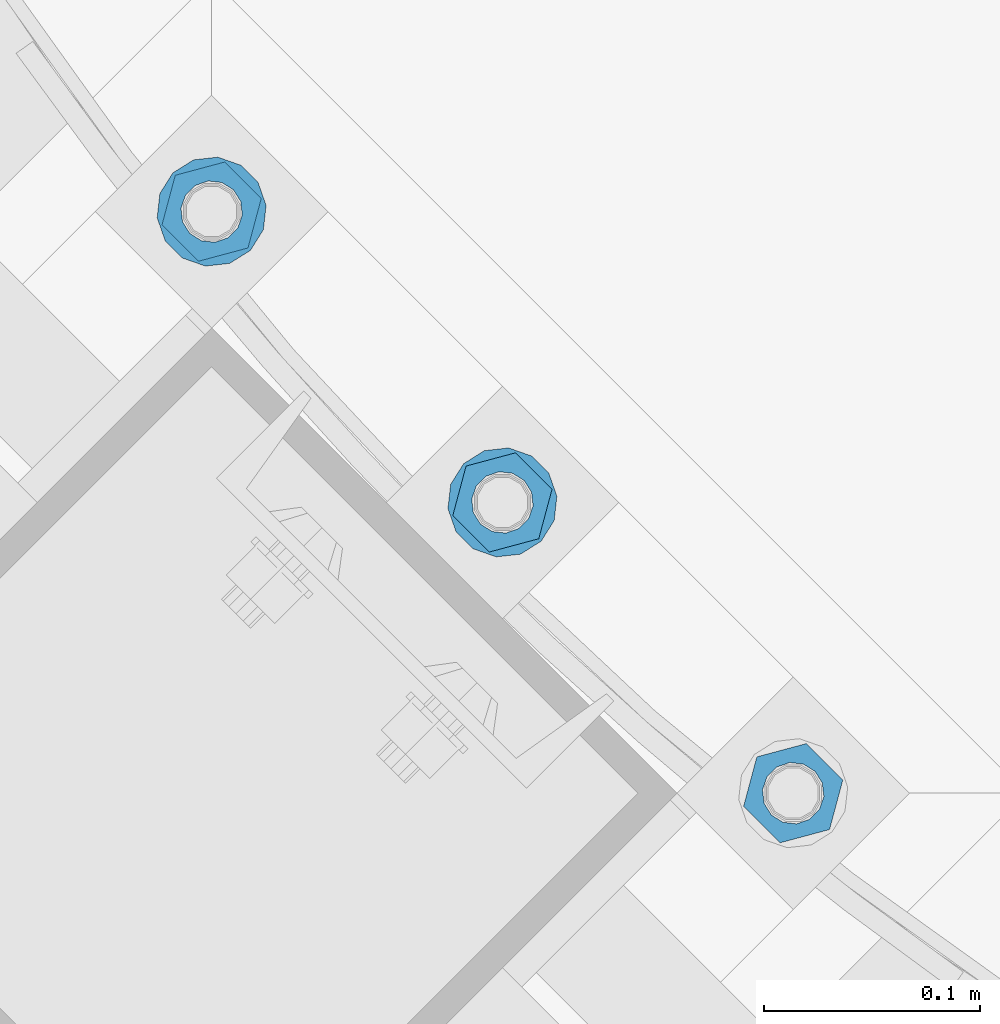
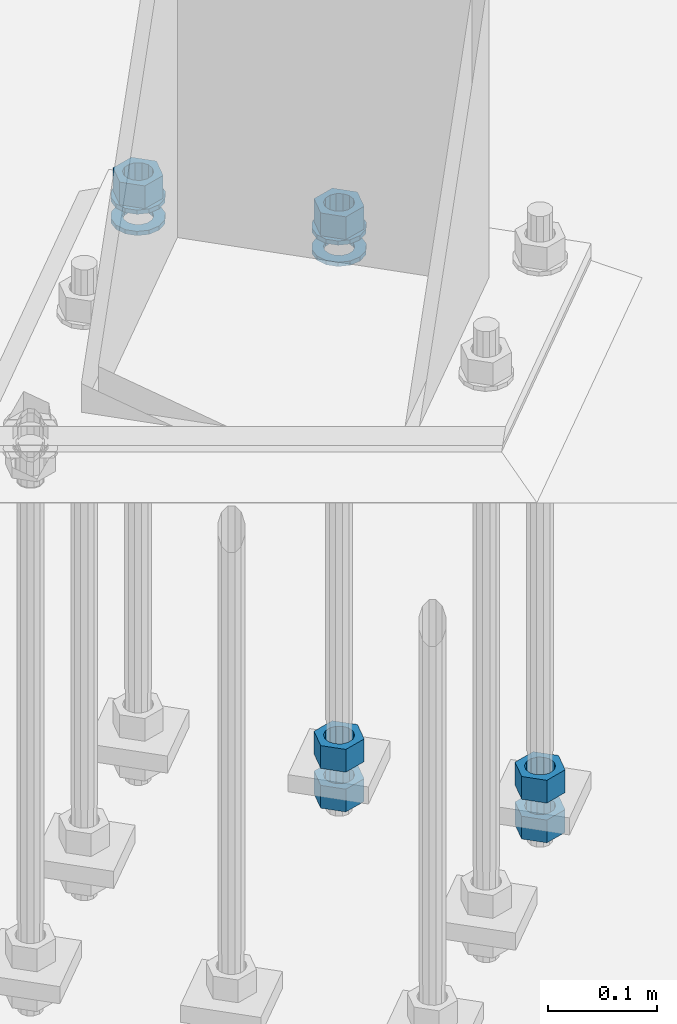
# One storey, part 879 of 1876: 10 columns, 1 element without a shape of its own.
"""IFC2X3 building model written with IfcOpenShell, lengths in millimetres."""

from ifc_helpers import new_model, si_unit, frame, origin_with_axes, place, context, subcontext, project, spatial, faceted_brep, material, type_object, element, aggregate, save


model = new_model("IFC2X3")

# Units and contexts
model_context = context("Model", 3, precision=1e-05, world=origin_with_axes())
body_context = subcontext(model_context, "Body", "Model", "MODEL_VIEW")
ifc_project = project(units=[si_unit("LENGTHUNIT", "METRE", prefix="MILLI"), si_unit("AREAUNIT", "SQUARE_METRE"), si_unit("VOLUMEUNIT", "CUBIC_METRE"), si_unit("MASSUNIT", "GRAM", prefix="KILO"), si_unit("TIMEUNIT", "SECOND"), si_unit("PLANEANGLEUNIT", "RADIAN"), si_unit("SOLIDANGLEUNIT", "STERADIAN"), si_unit("THERMODYNAMICTEMPERATUREUNIT", "DEGREE_CELSIUS"), si_unit("LUMINOUSINTENSITYUNIT", "LUMEN")], contexts=[model_context])

# Site, building, storey
site_placement = place(None, origin_with_axes())
site = spatial("IfcSite", under=ifc_project, at=site_placement, CompositionType="ELEMENT")
building_placement = place(site_placement, origin_with_axes())
building = spatial("IfcBuilding", under=site, at=building_placement, Name="Undefined", CompositionType="ELEMENT")
storey_placement = place(building_placement, origin_with_axes())
storey = spatial("IfcBuildingStorey", under=building, at=storey_placement, Name="Undefined", CompositionType="ELEMENT", Elevation=0.0)

# Assembly, columns
assembly_placement = place(storey_placement, origin_with_axes())
assembly = element("IfcElementAssembly", 1, at=assembly_placement, inside=storey, Name="TEMPLATE", AssemblyPlace="NOTDEFINED", PredefinedType="RIGID_FRAME")
ifc_material_1 = material(Name="STEEL/A563")
column_type_1 = type_object("IfcColumnType", Name="1_HEAVY_HEX_NUT", PredefinedType="NOTDEFINED")
column_1_placement = place(assembly_placement, frame((4052.33317214106, -10936.3778259279, -508.0), z_axis=(0.707106781186548, 0.707106781186547, 0.0), x_axis=(0.0, 0.0, -1.0)))
column_1 = element("IfcColumn", 2, at=column_1_placement, type_object=column_type_1, material=ifc_material_1, Name="NUT", ObjectType="1_HEAVY_HEX_NUT", context=body_context, shape_type="Brep", body=[
    faceted_brep([(0.0, -23.8099994659442, 9.09494701772928e-13), (0.0, -11.9099998474121, -20.6200008392352), (25.4, -11.9099998474157, -20.6200008392361), (25.4, -23.8099994659478, 0.0), (0.0, 11.9099998474157, -20.620000839237), (25.4, 11.9099998474121, -20.620000839237), (0.0, 23.8099994659478, 9.09494701772928e-13), (25.4, 23.8099994659442, 0.0), (0.0, 11.9099998474157, 20.620000839237), (25.4, 11.9099998474121, 20.620000839237), (0.0, -11.9099998474121, 20.6200008392389), (25.4, -11.9099998474157, 20.6200008392379), (0.0, 1.81898940354586e-12, 14.2899999618567), (0.0, 6.20019861543915, 12.8748450879584), (25.4, 6.20019861543733, 12.8748450879593), (25.4, 0.0, 14.2899999618558), (0.0, 11.1723718546473, 8.90966924477925), (25.4, 11.1723718546436, 8.90966924477925), (0.0, 13.9317198278914, 3.17982413774916), (25.4, 13.9317198278877, 3.17982413775007), (0.0, 13.9317198278914, -3.17982413774644), (25.4, 13.9317198278895, -3.17982413774735), (0.0, 11.1723718546473, -8.90966924477834), (25.4, 11.1723718546455, -8.90966924477925), (0.0, 6.20019861544279, -12.8748450879575), (25.4, 6.20019861543915, -12.8748450879584), (0.0, 3.63797880709171e-12, -14.2899999618548), (25.4, -3.63797880709171e-12, -14.2899999618548), (0.0, -6.20019861543733, -12.8748450879566), (25.4, -6.20019861544097, -12.8748450879584), (0.0, -11.1723718546455, -8.90966924477743), (25.4, -11.1723718546473, -8.90966924477834), (0.0, -13.9317198278877, -3.17982413774735), (25.4, -13.9317198278914, -3.17982413774826), (0.0, -13.9317198278895, 3.17982413774735), (25.4, -13.9317198278914, 3.17982413774826), (0.0, -11.1723718546455, 8.90966924477925), (25.4, -11.1723718546473, 8.90966924478016), (0.0, -6.20019861543915, 12.8748450879593), (25.4, -6.20019861544279, 12.8748450879593)], [[[0, 1, 2, 3]], [[1, 4, 5, 2]], [[4, 6, 7, 5]], [[6, 8, 9, 7]], [[8, 10, 11, 9]], [[10, 0, 3, 11]], [[12, 13, 14, 15]], [[13, 16, 17, 14]], [[16, 18, 19, 17]], [[18, 20, 21, 19]], [[20, 22, 23, 21]], [[22, 24, 25, 23]], [[24, 26, 27, 25]], [[26, 28, 29, 27]], [[28, 30, 31, 29]], [[30, 32, 33, 31]], [[32, 34, 35, 33]], [[34, 36, 37, 35]], [[36, 38, 39, 37]], [[38, 12, 15, 39]], [[5, 7, 9, 11, 3, 2], [17, 19, 21, 23, 25, 27, 29, 31, 33, 35, 37, 39, 15, 14]], [[10, 8, 6, 4, 1, 0], [38, 36, 34, 32, 30, 28, 26, 24, 22, 20, 18, 16, 13, 12]]]),
])
column_2_placement = place(assembly_placement, frame((4052.33317214106, -10936.3778259279, -552.45), z_axis=(0.707106781186548, 0.707106781186547, 0.0), x_axis=(0.0, 0.0, -1.0)))
column_2 = element("IfcColumn", 3, at=column_2_placement, type_object=column_type_1, material=ifc_material_1, Name="NUT", ObjectType="1_HEAVY_HEX_NUT", context=body_context, shape_type="Brep", body=[
    faceted_brep([(0.0, -23.8099994659442, 9.09494701772928e-13), (0.0, -11.9099998474121, -20.6200008392352), (25.4, -11.9099998474157, -20.6200008392361), (25.4, -23.8099994659478, 0.0), (0.0, 11.9099998474157, -20.620000839237), (25.4, 11.9099998474121, -20.620000839237), (0.0, 23.8099994659478, 9.09494701772928e-13), (25.4, 23.8099994659442, 0.0), (0.0, 11.9099998474157, 20.620000839237), (25.4, 11.9099998474121, 20.620000839237), (0.0, -11.9099998474121, 20.6200008392389), (25.4, -11.9099998474157, 20.6200008392379), (0.0, 1.81898940354586e-12, 14.2899999618567), (0.0, 6.20019861543915, 12.8748450879584), (25.4, 6.20019861543733, 12.8748450879593), (25.4, 0.0, 14.2899999618558), (0.0, 11.1723718546473, 8.90966924477925), (25.4, 11.1723718546436, 8.90966924477925), (0.0, 13.9317198278914, 3.17982413774916), (25.4, 13.9317198278877, 3.17982413775007), (0.0, 13.9317198278914, -3.17982413774644), (25.4, 13.9317198278895, -3.17982413774735), (0.0, 11.1723718546473, -8.90966924477834), (25.4, 11.1723718546455, -8.90966924477925), (0.0, 6.20019861544279, -12.8748450879575), (25.4, 6.20019861543915, -12.8748450879584), (0.0, 3.63797880709171e-12, -14.2899999618548), (25.4, -3.63797880709171e-12, -14.2899999618548), (0.0, -6.20019861543733, -12.8748450879566), (25.4, -6.20019861544097, -12.8748450879584), (0.0, -11.1723718546455, -8.90966924477743), (25.4, -11.1723718546473, -8.90966924477834), (0.0, -13.9317198278877, -3.17982413774735), (25.4, -13.9317198278914, -3.17982413774826), (0.0, -13.9317198278895, 3.17982413774735), (25.4, -13.9317198278914, 3.17982413774826), (0.0, -11.1723718546455, 8.90966924477925), (25.4, -11.1723718546473, 8.90966924478016), (0.0, -6.20019861543915, 12.8748450879593), (25.4, -6.20019861544279, 12.8748450879593)], [[[0, 1, 2, 3]], [[1, 4, 5, 2]], [[4, 6, 7, 5]], [[6, 8, 9, 7]], [[8, 10, 11, 9]], [[10, 0, 3, 11]], [[12, 13, 14, 15]], [[13, 16, 17, 14]], [[16, 18, 19, 17]], [[18, 20, 21, 19]], [[20, 22, 23, 21]], [[22, 24, 25, 23]], [[24, 26, 27, 25]], [[26, 28, 29, 27]], [[28, 30, 31, 29]], [[30, 32, 33, 31]], [[32, 34, 35, 33]], [[34, 36, 37, 35]], [[36, 38, 39, 37]], [[38, 12, 15, 39]], [[5, 7, 9, 11, 3, 2], [17, 19, 21, 23, 25, 27, 29, 31, 33, 35, 37, 39, 15, 14]], [[10, 8, 6, 4, 1, 0], [38, 36, 34, 32, 30, 28, 26, 24, 22, 20, 18, 16, 13, 12]]]),
])
column_3_placement = place(assembly_placement, frame((3917.62933032491, -10801.6739841117, 87.3125), z_axis=(0.707106781186548, 0.707106781186547, 0.0), x_axis=(0.0, 0.0, -1.0)))
column_3 = element("IfcColumn", 4, at=column_3_placement, type_object=column_type_1, material=ifc_material_1, Name="NUT", ObjectType="1_HEAVY_HEX_NUT", context=body_context, shape_type="Brep", body=[
    faceted_brep([(0.0, -23.8099994659442, 9.09494701772928e-13), (0.0, -11.9099998474121, -20.6200008392352), (25.4, -11.9099998474157, -20.6200008392361), (25.4, -23.8099994659478, 0.0), (0.0, 11.9099998474157, -20.620000839237), (25.4, 11.9099998474121, -20.620000839237), (0.0, 23.8099994659478, 9.09494701772928e-13), (25.4, 23.8099994659442, 0.0), (0.0, 11.9099998474157, 20.620000839237), (25.4, 11.9099998474121, 20.620000839237), (0.0, -11.9099998474121, 20.6200008392389), (25.4, -11.9099998474157, 20.6200008392379), (0.0, 1.81898940354586e-12, 14.2899999618567), (0.0, 6.20019861543915, 12.8748450879584), (25.4, 6.20019861543733, 12.8748450879593), (25.4, 0.0, 14.2899999618558), (0.0, 11.1723718546473, 8.90966924477925), (25.4, 11.1723718546436, 8.90966924477925), (0.0, 13.9317198278914, 3.17982413774916), (25.4, 13.9317198278877, 3.17982413775007), (0.0, 13.9317198278914, -3.17982413774644), (25.4, 13.9317198278895, -3.17982413774735), (0.0, 11.1723718546473, -8.90966924477834), (25.4, 11.1723718546455, -8.90966924477925), (0.0, 6.20019861544279, -12.8748450879575), (25.4, 6.20019861543915, -12.8748450879584), (0.0, 3.63797880709171e-12, -14.2899999618548), (25.4, -3.63797880709171e-12, -14.2899999618548), (0.0, -6.20019861543733, -12.8748450879566), (25.4, -6.20019861544097, -12.8748450879584), (0.0, -11.1723718546455, -8.90966924477743), (25.4, -11.1723718546473, -8.90966924477834), (0.0, -13.9317198278877, -3.17982413774735), (25.4, -13.9317198278914, -3.17982413774826), (0.0, -13.9317198278895, 3.17982413774735), (25.4, -13.9317198278914, 3.17982413774826), (0.0, -11.1723718546455, 8.90966924477925), (25.4, -11.1723718546473, 8.90966924478016), (0.0, -6.20019861543915, 12.8748450879593), (25.4, -6.20019861544279, 12.8748450879593)], [[[0, 1, 2, 3]], [[1, 4, 5, 2]], [[4, 6, 7, 5]], [[6, 8, 9, 7]], [[8, 10, 11, 9]], [[10, 0, 3, 11]], [[12, 13, 14, 15]], [[13, 16, 17, 14]], [[16, 18, 19, 17]], [[18, 20, 21, 19]], [[20, 22, 23, 21]], [[22, 24, 25, 23]], [[24, 26, 27, 25]], [[26, 28, 29, 27]], [[28, 30, 31, 29]], [[30, 32, 33, 31]], [[32, 34, 35, 33]], [[34, 36, 37, 35]], [[36, 38, 39, 37]], [[38, 12, 15, 39]], [[5, 7, 9, 11, 3, 2], [17, 19, 21, 23, 25, 27, 29, 31, 33, 35, 37, 39, 15, 14]], [[10, 8, 6, 4, 1, 0], [38, 36, 34, 32, 30, 28, 26, 24, 22, 20, 18, 16, 13, 12]]]),
])
column_4_placement = place(assembly_placement, frame((3917.62933032491, -10801.6739841117, -508.0), z_axis=(0.707106781186548, 0.707106781186547, 0.0), x_axis=(0.0, 0.0, -1.0)))
column_4 = element("IfcColumn", 5, at=column_4_placement, type_object=column_type_1, material=ifc_material_1, Name="NUT", ObjectType="1_HEAVY_HEX_NUT", context=body_context, shape_type="Brep", body=[
    faceted_brep([(0.0, -23.8099994659442, 9.09494701772928e-13), (0.0, -11.9099998474121, -20.6200008392352), (25.4, -11.9099998474157, -20.6200008392361), (25.4, -23.8099994659478, 0.0), (0.0, 11.9099998474157, -20.620000839237), (25.4, 11.9099998474121, -20.620000839237), (0.0, 23.8099994659478, 9.09494701772928e-13), (25.4, 23.8099994659442, 0.0), (0.0, 11.9099998474157, 20.620000839237), (25.4, 11.9099998474121, 20.620000839237), (0.0, -11.9099998474121, 20.6200008392389), (25.4, -11.9099998474157, 20.6200008392379), (0.0, 1.81898940354586e-12, 14.2899999618567), (0.0, 6.20019861543915, 12.8748450879584), (25.4, 6.20019861543733, 12.8748450879593), (25.4, 0.0, 14.2899999618558), (0.0, 11.1723718546473, 8.90966924477925), (25.4, 11.1723718546436, 8.90966924477925), (0.0, 13.9317198278914, 3.17982413774916), (25.4, 13.9317198278877, 3.17982413775007), (0.0, 13.9317198278914, -3.17982413774644), (25.4, 13.9317198278895, -3.17982413774735), (0.0, 11.1723718546473, -8.90966924477834), (25.4, 11.1723718546455, -8.90966924477925), (0.0, 6.20019861544279, -12.8748450879575), (25.4, 6.20019861543915, -12.8748450879584), (0.0, 3.63797880709171e-12, -14.2899999618548), (25.4, -3.63797880709171e-12, -14.2899999618548), (0.0, -6.20019861543733, -12.8748450879566), (25.4, -6.20019861544097, -12.8748450879584), (0.0, -11.1723718546455, -8.90966924477743), (25.4, -11.1723718546473, -8.90966924477834), (0.0, -13.9317198278877, -3.17982413774735), (25.4, -13.9317198278914, -3.17982413774826), (0.0, -13.9317198278895, 3.17982413774735), (25.4, -13.9317198278914, 3.17982413774826), (0.0, -11.1723718546455, 8.90966924477925), (25.4, -11.1723718546473, 8.90966924478016), (0.0, -6.20019861543915, 12.8748450879593), (25.4, -6.20019861544279, 12.8748450879593)], [[[0, 1, 2, 3]], [[1, 4, 5, 2]], [[4, 6, 7, 5]], [[6, 8, 9, 7]], [[8, 10, 11, 9]], [[10, 0, 3, 11]], [[12, 13, 14, 15]], [[13, 16, 17, 14]], [[16, 18, 19, 17]], [[18, 20, 21, 19]], [[20, 22, 23, 21]], [[22, 24, 25, 23]], [[24, 26, 27, 25]], [[26, 28, 29, 27]], [[28, 30, 31, 29]], [[30, 32, 33, 31]], [[32, 34, 35, 33]], [[34, 36, 37, 35]], [[36, 38, 39, 37]], [[38, 12, 15, 39]], [[5, 7, 9, 11, 3, 2], [17, 19, 21, 23, 25, 27, 29, 31, 33, 35, 37, 39, 15, 14]], [[10, 8, 6, 4, 1, 0], [38, 36, 34, 32, 30, 28, 26, 24, 22, 20, 18, 16, 13, 12]]]),
])
column_5_placement = place(assembly_placement, frame((3917.62933032491, -10801.6739841117, -552.45), z_axis=(0.707106781186548, 0.707106781186547, 0.0), x_axis=(0.0, 0.0, -1.0)))
column_5 = element("IfcColumn", 6, at=column_5_placement, type_object=column_type_1, material=ifc_material_1, Name="NUT", ObjectType="1_HEAVY_HEX_NUT", context=body_context, shape_type="Brep", body=[
    faceted_brep([(0.0, -23.8099994659442, 9.09494701772928e-13), (0.0, -11.9099998474121, -20.6200008392352), (25.4, -11.9099998474157, -20.6200008392361), (25.4, -23.8099994659478, 0.0), (0.0, 11.9099998474157, -20.620000839237), (25.4, 11.9099998474121, -20.620000839237), (0.0, 23.8099994659478, 9.09494701772928e-13), (25.4, 23.8099994659442, 0.0), (0.0, 11.9099998474157, 20.620000839237), (25.4, 11.9099998474121, 20.620000839237), (0.0, -11.9099998474121, 20.6200008392389), (25.4, -11.9099998474157, 20.6200008392379), (0.0, 1.81898940354586e-12, 14.2899999618567), (0.0, 6.20019861543915, 12.8748450879584), (25.4, 6.20019861543733, 12.8748450879593), (25.4, 0.0, 14.2899999618558), (0.0, 11.1723718546473, 8.90966924477925), (25.4, 11.1723718546436, 8.90966924477925), (0.0, 13.9317198278914, 3.17982413774916), (25.4, 13.9317198278877, 3.17982413775007), (0.0, 13.9317198278914, -3.17982413774644), (25.4, 13.9317198278895, -3.17982413774735), (0.0, 11.1723718546473, -8.90966924477834), (25.4, 11.1723718546455, -8.90966924477925), (0.0, 6.20019861544279, -12.8748450879575), (25.4, 6.20019861543915, -12.8748450879584), (0.0, 3.63797880709171e-12, -14.2899999618548), (25.4, -3.63797880709171e-12, -14.2899999618548), (0.0, -6.20019861543733, -12.8748450879566), (25.4, -6.20019861544097, -12.8748450879584), (0.0, -11.1723718546455, -8.90966924477743), (25.4, -11.1723718546473, -8.90966924477834), (0.0, -13.9317198278877, -3.17982413774735), (25.4, -13.9317198278914, -3.17982413774826), (0.0, -13.9317198278895, 3.17982413774735), (25.4, -13.9317198278914, 3.17982413774826), (0.0, -11.1723718546455, 8.90966924477925), (25.4, -11.1723718546473, 8.90966924478016), (0.0, -6.20019861543915, 12.8748450879593), (25.4, -6.20019861544279, 12.8748450879593)], [[[0, 1, 2, 3]], [[1, 4, 5, 2]], [[4, 6, 7, 5]], [[6, 8, 9, 7]], [[8, 10, 11, 9]], [[10, 0, 3, 11]], [[12, 13, 14, 15]], [[13, 16, 17, 14]], [[16, 18, 19, 17]], [[18, 20, 21, 19]], [[20, 22, 23, 21]], [[22, 24, 25, 23]], [[24, 26, 27, 25]], [[26, 28, 29, 27]], [[28, 30, 31, 29]], [[30, 32, 33, 31]], [[32, 34, 35, 33]], [[34, 36, 37, 35]], [[36, 38, 39, 37]], [[38, 12, 15, 39]], [[5, 7, 9, 11, 3, 2], [17, 19, 21, 23, 25, 27, 29, 31, 33, 35, 37, 39, 15, 14]], [[10, 8, 6, 4, 1, 0], [38, 36, 34, 32, 30, 28, 26, 24, 22, 20, 18, 16, 13, 12]]]),
])
column_6_placement = place(assembly_placement, frame((3782.92548850875, -10666.9701422955, 87.3125), z_axis=(-0.707106781186547, -0.707106781186548, 0.0), x_axis=(0.0, 0.0, -1.0)))
column_6 = element("IfcColumn", 7, at=column_6_placement, type_object=column_type_1, material=ifc_material_1, Name="NUT", ObjectType="1_HEAVY_HEX_NUT", context=body_context, shape_type="Brep", body=[
    faceted_brep([(0.0, -23.8099994659442, 9.09494701772928e-13), (0.0, -11.9099998474121, -20.6200008392352), (25.4, -11.9099998474157, -20.6200008392361), (25.4, -23.8099994659478, 0.0), (0.0, 11.9099998474157, -20.620000839237), (25.4, 11.9099998474121, -20.620000839237), (0.0, 23.8099994659478, 9.09494701772928e-13), (25.4, 23.8099994659442, 0.0), (0.0, 11.9099998474157, 20.620000839237), (25.4, 11.9099998474121, 20.620000839237), (0.0, -11.9099998474121, 20.6200008392389), (25.4, -11.9099998474157, 20.6200008392379), (0.0, 1.81898940354586e-12, 14.2899999618567), (0.0, 6.20019861543915, 12.8748450879584), (25.4, 6.20019861543733, 12.8748450879593), (25.4, 0.0, 14.2899999618558), (0.0, 11.1723718546473, 8.90966924477925), (25.4, 11.1723718546436, 8.90966924477925), (0.0, 13.9317198278914, 3.17982413774916), (25.4, 13.9317198278877, 3.17982413775007), (0.0, 13.9317198278914, -3.17982413774644), (25.4, 13.9317198278895, -3.17982413774735), (0.0, 11.1723718546473, -8.90966924477834), (25.4, 11.1723718546455, -8.90966924477925), (0.0, 6.20019861544279, -12.8748450879575), (25.4, 6.20019861543915, -12.8748450879584), (0.0, 3.63797880709171e-12, -14.2899999618548), (25.4, -3.63797880709171e-12, -14.2899999618548), (0.0, -6.20019861543733, -12.8748450879566), (25.4, -6.20019861544097, -12.8748450879584), (0.0, -11.1723718546455, -8.90966924477743), (25.4, -11.1723718546473, -8.90966924477834), (0.0, -13.9317198278877, -3.17982413774735), (25.4, -13.9317198278914, -3.17982413774826), (0.0, -13.9317198278895, 3.17982413774735), (25.4, -13.9317198278914, 3.17982413774826), (0.0, -11.1723718546455, 8.90966924477925), (25.4, -11.1723718546473, 8.90966924478016), (0.0, -6.20019861543915, 12.8748450879593), (25.4, -6.20019861544279, 12.8748450879593)], [[[0, 1, 2, 3]], [[1, 4, 5, 2]], [[4, 6, 7, 5]], [[6, 8, 9, 7]], [[8, 10, 11, 9]], [[10, 0, 3, 11]], [[12, 13, 14, 15]], [[13, 16, 17, 14]], [[16, 18, 19, 17]], [[18, 20, 21, 19]], [[20, 22, 23, 21]], [[22, 24, 25, 23]], [[24, 26, 27, 25]], [[26, 28, 29, 27]], [[28, 30, 31, 29]], [[30, 32, 33, 31]], [[32, 34, 35, 33]], [[34, 36, 37, 35]], [[36, 38, 39, 37]], [[38, 12, 15, 39]], [[5, 7, 9, 11, 3, 2], [17, 19, 21, 23, 25, 27, 29, 31, 33, 35, 37, 39, 15, 14]], [[10, 8, 6, 4, 1, 0], [38, 36, 34, 32, 30, 28, 26, 24, 22, 20, 18, 16, 13, 12]]]),
])
ifc_material_2 = material(Name="STEEL/F436")
column_type_2 = type_object("IfcColumnType", Name="1_WASHER", PredefinedType="NOTDEFINED")
column_7_placement = place(assembly_placement, frame((3917.62933032491, -10801.6739841117, 38.1), z_axis=(0.707106781186548, 0.707106781186547, 0.0), x_axis=(0.0, 0.0, -1.0)))
column_7 = element("IfcColumn", 8, at=column_7_placement, type_object=column_type_2, material=ifc_material_2, Name="WASHER", ObjectType="1_WASHER", context=body_context, shape_type="Brep", body=[
    faceted_brep([(0.0, -25.3999996185375, 0.0), (0.0, -22.8846089010331, -11.0206468080742), (4.7625, -22.8846089010331, -11.0206468080742), (4.7625, -25.3999996185375, 0.0), (0.0, -15.8366407293743, -19.8585193564477), (4.7625, -15.8366407293743, -19.8585193564477), (0.0, -5.65203163760816, -24.7631685975166), (4.7625, -5.65203163760816, -24.7631685975166), (0.0, 5.65203163760452, -24.7631685975166), (4.7625, 5.65203163760452, -24.7631685975166), (0.0, 15.8366407293706, -19.858519356445), (4.7625, 15.8366407293706, -19.858519356445), (0.0, 22.8846089010331, -11.0206468080733), (4.7625, 22.8846089010331, -11.0206468080733), (0.0, 25.3999996185339, 9.09494701772928e-13), (4.7625, 25.3999996185339, 9.09494701772928e-13), (0.0, 22.8846089010331, 11.0206468080751), (4.7625, 22.8846089010331, 11.0206468080751), (0.0, 15.8366407293706, 19.8585193564486), (4.7625, 15.8366407293706, 19.8585193564486), (0.0, 5.65203163760452, 24.7631685975175), (4.7625, 5.65203163760452, 24.7631685975175), (0.0, -5.65203163760816, 24.7631685975175), (4.7625, -5.65203163760816, 24.7631685975175), (0.0, -15.8366407293724, 19.8585193564459), (4.7625, -15.8366407293724, 19.8585193564459), (0.0, -22.8846089010367, 11.0206468080751), (4.7625, -22.8846089010367, 11.0206468080751), (0.0, 1.81898940354586e-12, 14.2899999618567), (0.0, 6.20019861543915, 12.8748450879584), (4.7625, 6.20019861543733, 12.8748450879593), (4.7625, 0.0, 14.2899999618558), (0.0, 11.1723718546473, 8.90966924477925), (4.7625, 11.1723718546436, 8.90966924477925), (0.0, 13.9317198278914, 3.17982413774916), (4.7625, 13.9317198278877, 3.17982413775007), (0.0, 13.9317198278914, -3.17982413774644), (4.7625, 13.9317198278895, -3.17982413774735), (0.0, 11.1723718546473, -8.90966924477834), (4.7625, 11.1723718546455, -8.90966924477925), (0.0, 6.20019861544279, -12.8748450879575), (4.7625, 6.20019861543915, -12.8748450879584), (0.0, 3.63797880709171e-12, -14.2899999618548), (4.7625, -3.63797880709171e-12, -14.2899999618548), (0.0, -6.20019861543733, -12.8748450879566), (4.7625, -6.20019861544097, -12.8748450879584), (0.0, -11.1723718546455, -8.90966924477743), (4.7625, -11.1723718546473, -8.90966924477834), (0.0, -13.9317198278877, -3.17982413774735), (4.7625, -13.9317198278914, -3.17982413774826), (0.0, -13.9317198278895, 3.17982413774735), (4.7625, -13.9317198278914, 3.17982413774826), (0.0, -11.1723718546455, 8.90966924477925), (4.7625, -11.1723718546473, 8.90966924478016), (0.0, -6.20019861543915, 12.8748450879593), (4.7625, -6.20019861544279, 12.8748450879593)], [[[0, 1, 2, 3]], [[1, 4, 5, 2]], [[4, 6, 7, 5]], [[6, 8, 9, 7]], [[8, 10, 11, 9]], [[10, 12, 13, 11]], [[12, 14, 15, 13]], [[14, 16, 17, 15]], [[16, 18, 19, 17]], [[18, 20, 21, 19]], [[20, 22, 23, 21]], [[22, 24, 25, 23]], [[24, 26, 27, 25]], [[26, 0, 3, 27]], [[28, 29, 30, 31]], [[29, 32, 33, 30]], [[32, 34, 35, 33]], [[34, 36, 37, 35]], [[36, 38, 39, 37]], [[38, 40, 41, 39]], [[40, 42, 43, 41]], [[42, 44, 45, 43]], [[44, 46, 47, 45]], [[46, 48, 49, 47]], [[48, 50, 51, 49]], [[50, 52, 53, 51]], [[52, 54, 55, 53]], [[54, 28, 31, 55]], [[5, 7, 9, 11, 13, 15, 17, 19, 21, 23, 25, 27, 3, 2], [33, 35, 37, 39, 41, 43, 45, 47, 49, 51, 53, 55, 31, 30]], [[26, 24, 22, 20, 18, 16, 14, 12, 10, 8, 6, 4, 1, 0], [54, 52, 50, 48, 46, 44, 42, 40, 38, 36, 34, 32, 29, 28]]]),
])
column_8_placement = place(assembly_placement, frame((3917.62933032491, -10801.6739841117, 61.9125), z_axis=(0.707106781186548, 0.707106781186547, 0.0), x_axis=(0.0, 0.0, -1.0)))
column_8 = element("IfcColumn", 9, at=column_8_placement, type_object=column_type_2, material=ifc_material_2, Name="WASHER", ObjectType="1_WASHER", context=body_context, shape_type="Brep", body=[
    faceted_brep([(0.0, -25.3999996185375, 0.0), (0.0, -22.8846089010331, -11.0206468080742), (4.7625, -22.8846089010331, -11.0206468080742), (4.7625, -25.3999996185375, 0.0), (0.0, -15.8366407293743, -19.8585193564477), (4.7625, -15.8366407293743, -19.8585193564477), (0.0, -5.65203163760816, -24.7631685975166), (4.7625, -5.65203163760816, -24.7631685975166), (0.0, 5.65203163760452, -24.7631685975166), (4.7625, 5.65203163760452, -24.7631685975166), (0.0, 15.8366407293706, -19.858519356445), (4.7625, 15.8366407293706, -19.858519356445), (0.0, 22.8846089010331, -11.0206468080733), (4.7625, 22.8846089010331, -11.0206468080733), (0.0, 25.3999996185339, 9.09494701772928e-13), (4.7625, 25.3999996185339, 9.09494701772928e-13), (0.0, 22.8846089010331, 11.0206468080751), (4.7625, 22.8846089010331, 11.0206468080751), (0.0, 15.8366407293706, 19.8585193564486), (4.7625, 15.8366407293706, 19.8585193564486), (0.0, 5.65203163760452, 24.7631685975175), (4.7625, 5.65203163760452, 24.7631685975175), (0.0, -5.65203163760816, 24.7631685975175), (4.7625, -5.65203163760816, 24.7631685975175), (0.0, -15.8366407293724, 19.8585193564459), (4.7625, -15.8366407293724, 19.8585193564459), (0.0, -22.8846089010367, 11.0206468080751), (4.7625, -22.8846089010367, 11.0206468080751), (0.0, 1.81898940354586e-12, 14.2899999618567), (0.0, 6.20019861543915, 12.8748450879584), (4.7625, 6.20019861543733, 12.8748450879593), (4.7625, 0.0, 14.2899999618558), (0.0, 11.1723718546473, 8.90966924477925), (4.7625, 11.1723718546436, 8.90966924477925), (0.0, 13.9317198278914, 3.17982413774916), (4.7625, 13.9317198278877, 3.17982413775007), (0.0, 13.9317198278914, -3.17982413774644), (4.7625, 13.9317198278895, -3.17982413774735), (0.0, 11.1723718546473, -8.90966924477834), (4.7625, 11.1723718546455, -8.90966924477925), (0.0, 6.20019861544279, -12.8748450879575), (4.7625, 6.20019861543915, -12.8748450879584), (0.0, 3.63797880709171e-12, -14.2899999618548), (4.7625, -3.63797880709171e-12, -14.2899999618548), (0.0, -6.20019861543733, -12.8748450879566), (4.7625, -6.20019861544097, -12.8748450879584), (0.0, -11.1723718546455, -8.90966924477743), (4.7625, -11.1723718546473, -8.90966924477834), (0.0, -13.9317198278877, -3.17982413774735), (4.7625, -13.9317198278914, -3.17982413774826), (0.0, -13.9317198278895, 3.17982413774735), (4.7625, -13.9317198278914, 3.17982413774826), (0.0, -11.1723718546455, 8.90966924477925), (4.7625, -11.1723718546473, 8.90966924478016), (0.0, -6.20019861543915, 12.8748450879593), (4.7625, -6.20019861544279, 12.8748450879593)], [[[0, 1, 2, 3]], [[1, 4, 5, 2]], [[4, 6, 7, 5]], [[6, 8, 9, 7]], [[8, 10, 11, 9]], [[10, 12, 13, 11]], [[12, 14, 15, 13]], [[14, 16, 17, 15]], [[16, 18, 19, 17]], [[18, 20, 21, 19]], [[20, 22, 23, 21]], [[22, 24, 25, 23]], [[24, 26, 27, 25]], [[26, 0, 3, 27]], [[28, 29, 30, 31]], [[29, 32, 33, 30]], [[32, 34, 35, 33]], [[34, 36, 37, 35]], [[36, 38, 39, 37]], [[38, 40, 41, 39]], [[40, 42, 43, 41]], [[42, 44, 45, 43]], [[44, 46, 47, 45]], [[46, 48, 49, 47]], [[48, 50, 51, 49]], [[50, 52, 53, 51]], [[52, 54, 55, 53]], [[54, 28, 31, 55]], [[5, 7, 9, 11, 13, 15, 17, 19, 21, 23, 25, 27, 3, 2], [33, 35, 37, 39, 41, 43, 45, 47, 49, 51, 53, 55, 31, 30]], [[26, 24, 22, 20, 18, 16, 14, 12, 10, 8, 6, 4, 1, 0], [54, 52, 50, 48, 46, 44, 42, 40, 38, 36, 34, 32, 29, 28]]]),
])
column_9_placement = place(assembly_placement, frame((3782.92548850875, -10666.9701422955, 38.1), z_axis=(-0.707106781186547, -0.707106781186548, 0.0), x_axis=(0.0, 0.0, -1.0)))
column_9 = element("IfcColumn", 10, at=column_9_placement, type_object=column_type_2, material=ifc_material_2, Name="WASHER", ObjectType="1_WASHER", context=body_context, shape_type="Brep", body=[
    faceted_brep([(0.0, -25.3999996185375, 0.0), (0.0, -22.8846089010331, -11.0206468080742), (4.7625, -22.8846089010331, -11.0206468080742), (4.7625, -25.3999996185375, 0.0), (0.0, -15.8366407293743, -19.8585193564477), (4.7625, -15.8366407293743, -19.8585193564477), (0.0, -5.65203163760816, -24.7631685975166), (4.7625, -5.65203163760816, -24.7631685975166), (0.0, 5.65203163760452, -24.7631685975166), (4.7625, 5.65203163760452, -24.7631685975166), (0.0, 15.8366407293706, -19.858519356445), (4.7625, 15.8366407293706, -19.858519356445), (0.0, 22.8846089010331, -11.0206468080733), (4.7625, 22.8846089010331, -11.0206468080733), (0.0, 25.3999996185339, 9.09494701772928e-13), (4.7625, 25.3999996185339, 9.09494701772928e-13), (0.0, 22.8846089010331, 11.0206468080751), (4.7625, 22.8846089010331, 11.0206468080751), (0.0, 15.8366407293706, 19.8585193564486), (4.7625, 15.8366407293706, 19.8585193564486), (0.0, 5.65203163760452, 24.7631685975175), (4.7625, 5.65203163760452, 24.7631685975175), (0.0, -5.65203163760816, 24.7631685975175), (4.7625, -5.65203163760816, 24.7631685975175), (0.0, -15.8366407293724, 19.8585193564459), (4.7625, -15.8366407293724, 19.8585193564459), (0.0, -22.8846089010367, 11.0206468080751), (4.7625, -22.8846089010367, 11.0206468080751), (0.0, 1.81898940354586e-12, 14.2899999618567), (0.0, 6.20019861543915, 12.8748450879584), (4.7625, 6.20019861543733, 12.8748450879593), (4.7625, 0.0, 14.2899999618558), (0.0, 11.1723718546473, 8.90966924477925), (4.7625, 11.1723718546436, 8.90966924477925), (0.0, 13.9317198278914, 3.17982413774916), (4.7625, 13.9317198278877, 3.17982413775007), (0.0, 13.9317198278914, -3.17982413774644), (4.7625, 13.9317198278895, -3.17982413774735), (0.0, 11.1723718546473, -8.90966924477834), (4.7625, 11.1723718546455, -8.90966924477925), (0.0, 6.20019861544279, -12.8748450879575), (4.7625, 6.20019861543915, -12.8748450879584), (0.0, 3.63797880709171e-12, -14.2899999618548), (4.7625, -3.63797880709171e-12, -14.2899999618548), (0.0, -6.20019861543733, -12.8748450879566), (4.7625, -6.20019861544097, -12.8748450879584), (0.0, -11.1723718546455, -8.90966924477743), (4.7625, -11.1723718546473, -8.90966924477834), (0.0, -13.9317198278877, -3.17982413774735), (4.7625, -13.9317198278914, -3.17982413774826), (0.0, -13.9317198278895, 3.17982413774735), (4.7625, -13.9317198278914, 3.17982413774826), (0.0, -11.1723718546455, 8.90966924477925), (4.7625, -11.1723718546473, 8.90966924478016), (0.0, -6.20019861543915, 12.8748450879593), (4.7625, -6.20019861544279, 12.8748450879593)], [[[0, 1, 2, 3]], [[1, 4, 5, 2]], [[4, 6, 7, 5]], [[6, 8, 9, 7]], [[8, 10, 11, 9]], [[10, 12, 13, 11]], [[12, 14, 15, 13]], [[14, 16, 17, 15]], [[16, 18, 19, 17]], [[18, 20, 21, 19]], [[20, 22, 23, 21]], [[22, 24, 25, 23]], [[24, 26, 27, 25]], [[26, 0, 3, 27]], [[28, 29, 30, 31]], [[29, 32, 33, 30]], [[32, 34, 35, 33]], [[34, 36, 37, 35]], [[36, 38, 39, 37]], [[38, 40, 41, 39]], [[40, 42, 43, 41]], [[42, 44, 45, 43]], [[44, 46, 47, 45]], [[46, 48, 49, 47]], [[48, 50, 51, 49]], [[50, 52, 53, 51]], [[52, 54, 55, 53]], [[54, 28, 31, 55]], [[5, 7, 9, 11, 13, 15, 17, 19, 21, 23, 25, 27, 3, 2], [33, 35, 37, 39, 41, 43, 45, 47, 49, 51, 53, 55, 31, 30]], [[26, 24, 22, 20, 18, 16, 14, 12, 10, 8, 6, 4, 1, 0], [54, 52, 50, 48, 46, 44, 42, 40, 38, 36, 34, 32, 29, 28]]]),
])
column_10_placement = place(assembly_placement, frame((3782.92548850875, -10666.9701422955, 61.9125), z_axis=(-0.707106781186547, -0.707106781186548, 0.0), x_axis=(0.0, 0.0, -1.0)))
column_10 = element("IfcColumn", 11, at=column_10_placement, type_object=column_type_2, material=ifc_material_2, Name="WASHER", ObjectType="1_WASHER", context=body_context, shape_type="Brep", body=[
    faceted_brep([(0.0, -25.3999996185375, 0.0), (0.0, -22.8846089010331, -11.0206468080742), (4.7625, -22.8846089010331, -11.0206468080742), (4.7625, -25.3999996185375, 0.0), (0.0, -15.8366407293743, -19.8585193564477), (4.7625, -15.8366407293743, -19.8585193564477), (0.0, -5.65203163760816, -24.7631685975166), (4.7625, -5.65203163760816, -24.7631685975166), (0.0, 5.65203163760452, -24.7631685975166), (4.7625, 5.65203163760452, -24.7631685975166), (0.0, 15.8366407293706, -19.858519356445), (4.7625, 15.8366407293706, -19.858519356445), (0.0, 22.8846089010331, -11.0206468080733), (4.7625, 22.8846089010331, -11.0206468080733), (0.0, 25.3999996185339, 9.09494701772928e-13), (4.7625, 25.3999996185339, 9.09494701772928e-13), (0.0, 22.8846089010331, 11.0206468080751), (4.7625, 22.8846089010331, 11.0206468080751), (0.0, 15.8366407293706, 19.8585193564486), (4.7625, 15.8366407293706, 19.8585193564486), (0.0, 5.65203163760452, 24.7631685975175), (4.7625, 5.65203163760452, 24.7631685975175), (0.0, -5.65203163760816, 24.7631685975175), (4.7625, -5.65203163760816, 24.7631685975175), (0.0, -15.8366407293724, 19.8585193564459), (4.7625, -15.8366407293724, 19.8585193564459), (0.0, -22.8846089010367, 11.0206468080751), (4.7625, -22.8846089010367, 11.0206468080751), (0.0, 1.81898940354586e-12, 14.2899999618567), (0.0, 6.20019861543915, 12.8748450879584), (4.7625, 6.20019861543733, 12.8748450879593), (4.7625, 0.0, 14.2899999618558), (0.0, 11.1723718546473, 8.90966924477925), (4.7625, 11.1723718546436, 8.90966924477925), (0.0, 13.9317198278914, 3.17982413774916), (4.7625, 13.9317198278877, 3.17982413775007), (0.0, 13.9317198278914, -3.17982413774644), (4.7625, 13.9317198278895, -3.17982413774735), (0.0, 11.1723718546473, -8.90966924477834), (4.7625, 11.1723718546455, -8.90966924477925), (0.0, 6.20019861544279, -12.8748450879575), (4.7625, 6.20019861543915, -12.8748450879584), (0.0, 3.63797880709171e-12, -14.2899999618548), (4.7625, -3.63797880709171e-12, -14.2899999618548), (0.0, -6.20019861543733, -12.8748450879566), (4.7625, -6.20019861544097, -12.8748450879584), (0.0, -11.1723718546455, -8.90966924477743), (4.7625, -11.1723718546473, -8.90966924477834), (0.0, -13.9317198278877, -3.17982413774735), (4.7625, -13.9317198278914, -3.17982413774826), (0.0, -13.9317198278895, 3.17982413774735), (4.7625, -13.9317198278914, 3.17982413774826), (0.0, -11.1723718546455, 8.90966924477925), (4.7625, -11.1723718546473, 8.90966924478016), (0.0, -6.20019861543915, 12.8748450879593), (4.7625, -6.20019861544279, 12.8748450879593)], [[[0, 1, 2, 3]], [[1, 4, 5, 2]], [[4, 6, 7, 5]], [[6, 8, 9, 7]], [[8, 10, 11, 9]], [[10, 12, 13, 11]], [[12, 14, 15, 13]], [[14, 16, 17, 15]], [[16, 18, 19, 17]], [[18, 20, 21, 19]], [[20, 22, 23, 21]], [[22, 24, 25, 23]], [[24, 26, 27, 25]], [[26, 0, 3, 27]], [[28, 29, 30, 31]], [[29, 32, 33, 30]], [[32, 34, 35, 33]], [[34, 36, 37, 35]], [[36, 38, 39, 37]], [[38, 40, 41, 39]], [[40, 42, 43, 41]], [[42, 44, 45, 43]], [[44, 46, 47, 45]], [[46, 48, 49, 47]], [[48, 50, 51, 49]], [[50, 52, 53, 51]], [[52, 54, 55, 53]], [[54, 28, 31, 55]], [[5, 7, 9, 11, 13, 15, 17, 19, 21, 23, 25, 27, 3, 2], [33, 35, 37, 39, 41, 43, 45, 47, 49, 51, 53, 55, 31, 30]], [[26, 24, 22, 20, 18, 16, 14, 12, 10, 8, 6, 4, 1, 0], [54, 52, 50, 48, 46, 44, 42, 40, 38, 36, 34, 32, 29, 28]]]),
])
aggregate(assembly, [column_1, column_2, column_3, column_7, column_8, column_4, column_5, column_6, column_9, column_10])

save(model, "model.ifc")
